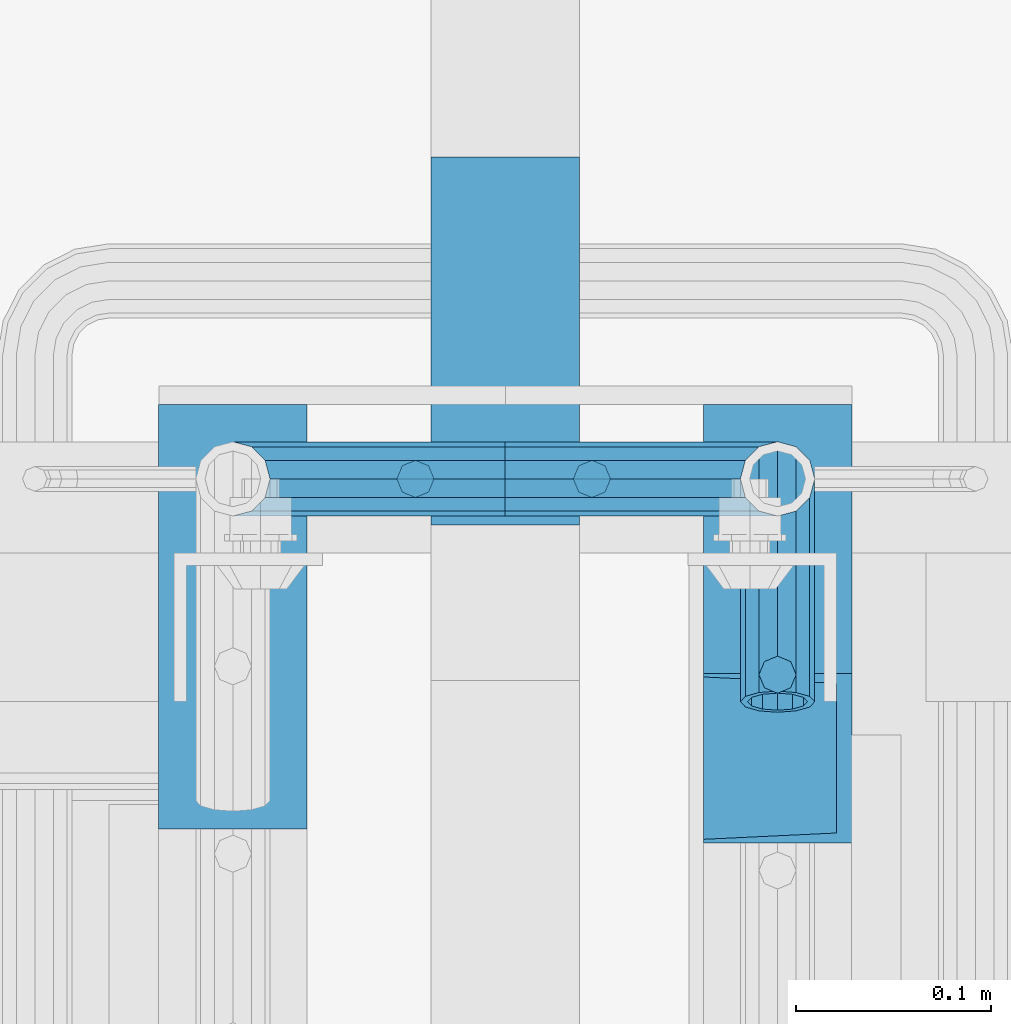
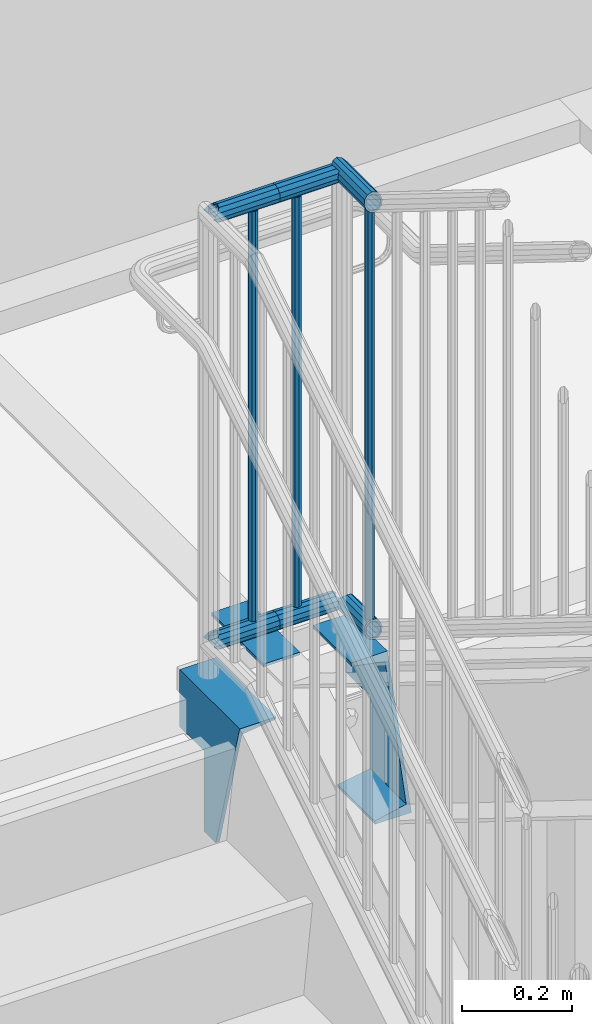
# One storey, part 1274 of 1763: 12 beams, 5 elements without a shape of their own.
"""IFC2X3 building model written with IfcOpenShell, lengths in millimetres."""

from ifc_helpers import new_model, si_unit, frame, origin_with_axes, place, context, subcontext, project, spatial, faceted_brep, material, type_object, element, aggregate, save


model = new_model("IFC2X3")

# Units and contexts
model_context = context("Model", 3, precision=1e-05, world=origin_with_axes())
body_context = subcontext(model_context, "Body", "Model", "MODEL_VIEW")
ifc_project = project(units=[si_unit("LENGTHUNIT", "METRE", prefix="MILLI"), si_unit("AREAUNIT", "SQUARE_METRE"), si_unit("VOLUMEUNIT", "CUBIC_METRE"), si_unit("MASSUNIT", "GRAM", prefix="KILO"), si_unit("TIMEUNIT", "SECOND"), si_unit("PLANEANGLEUNIT", "RADIAN"), si_unit("SOLIDANGLEUNIT", "STERADIAN"), si_unit("THERMODYNAMICTEMPERATUREUNIT", "DEGREE_CELSIUS"), si_unit("LUMINOUSINTENSITYUNIT", "LUMEN")], contexts=[model_context])

# Site, building, storey
site_placement = place(None, origin_with_axes())
site = spatial("IfcSite", under=ifc_project, at=site_placement, CompositionType="ELEMENT")
building_placement = place(site_placement, origin_with_axes())
building = spatial("IfcBuilding", under=site, at=building_placement, Name="Undefined", CompositionType="ELEMENT")
storey_placement = place(building_placement, origin_with_axes())
storey = spatial("IfcBuildingStorey", under=building, at=storey_placement, Name="Undefined", CompositionType="ELEMENT", Elevation=0.0)

# Assembly, beam
assembly_1_placement = place(storey_placement, origin_with_axes())
assembly_1 = element("IfcElementAssembly", 1, at=assembly_1_placement, inside=storey, Name="RAIL", AssemblyPlace="NOTDEFINED", PredefinedType="RIGID_FRAME")
ifc_material_1 = material(Name="STEEL/A513")
beam_type_1 = type_object("IfcBeamType", PredefinedType="NOTDEFINED")
beam_1_placement = place(assembly_1_placement, frame((-85419.6372736932, 36093.4000003696, 2852.7375000151), z_axis=(0.0, 0.0, -1.0), x_axis=(-1.0, 0.0, 0.0)))
beam_1 = element("IfcBeam", 2, at=beam_1_placement, type_object=beam_type_1, material=ifc_material_1, Name="RAIL", context=body_context, shape_type="Brep", body=[
    faceted_brep([(123.202216057922, -9.52500000000146, 16.4977839420935), (123.202216057922, -9.52500000034343, 11.4667123796135), (122.708787619966, -7.68349999999919, 13.3082123799554), (120.650000000009, 0.0, 15.3670000000002), (120.650000000009, 0.0, 19.0500000000002), (122.708787620155, 7.68349999999919, 13.3082123799554), (123.202216057922, 9.52499999965949, 11.4667123802974), (123.202216057922, 9.52500000000146, 16.4977839420935), (139.700000000012, 19.0500000000029, 0.0), (130.175000000017, 16.4977839420972, 9.52500000000009), (130.175000000017, 16.4977839420972, -9.52500000000009), (126.985428438216, 13.3082123799541, 7.68350000000009), (129.044216058261, 15.3669999999984, 0.0), (126.985428438216, 13.3082123799541, -7.68350000000009), (123.202216057922, 9.52499999965949, -11.4667123802974), (123.202216057922, 9.52500000000146, -16.4977839420935), (122.708787620155, 7.68349999999919, -13.3082123799554), (120.650000000009, 0.0, -15.3670000000002), (120.650000000009, 0.0, -19.0500000000002), (123.202216057922, -9.52500000034343, -11.4667123796135), (123.202216057922, -9.52500000000146, -16.4977839420935), (122.708787619966, -7.68349999999919, -13.3082123799554), (139.700000000012, -19.0500000003449, 0.0), (130.175000000017, -16.4977839420972, -9.52500000000009), (130.175000000017, -16.4977839420972, 9.52500000000009), (126.985428437532, -13.3082123799541, -7.68350000000009), (129.044216057577, -15.3669999999984, 0.0), (126.985428437532, -13.3082123799541, 7.68350000000009), (0.0, -16.4977839420899, -9.52500000000146), (0.0, -9.52499999999418, -16.4977839420935), (1.45519152283669e-11, 1.81898940354586e-12, -19.0499999999993), (0.0, 9.52499999999418, -16.4977839420935), (0.0, 16.4977839420899, -9.52500000000146), (0.0, 19.0500000000029, 0.0), (0.0, 16.4977839420899, 9.52500000000146), (0.0, 9.52499999999418, 16.4977839420935), (1.45519152283669e-11, 1.81898940354586e-12, 19.0499999999993), (0.0, -9.52499999999418, 16.4977839420935), (0.0, -16.4977839420899, 9.52500000000146), (0.0, -19.0500000000029, 0.0), (3.63797880709171e-12, -13.3082123799541, -7.68349999999737), (3.63797880709171e-12, -7.68349999999919, -13.3082123799522), (3.63797880709171e-12, 0.0, -15.3669999999956), (3.63797880709171e-12, 7.68349999999919, -13.3082123799522), (3.63797880709171e-12, 13.3082123799541, -7.68349999999737), (4.71409293822944e-08, 15.3669999999984, 0.0), (-1.81898940354586e-12, 13.3082123799541, 7.68349999999919), (-3.63797880709171e-12, 7.68349999999919, 13.3082123799531), (-1.81898940354586e-12, 0.0, 15.3669999999966), (-3.63797880709171e-12, -7.68349999999919, 13.3082123799531), (-1.81898940354586e-12, -13.3082123799541, 7.68349999999919), (4.71409293822944e-08, -15.3669999999984, 0.0)], [[[0, 1, 2, 3, 4]], [[4, 3, 5, 6, 7]], [[8, 9, 10]], [[7, 6, 11, 12, 13, 14, 15, 10, 9]], [[16, 17, 18, 15, 14]], [[19, 20, 18, 17, 21]], [[22, 23, 24]], [[24, 23, 20, 19, 25, 26, 27, 1, 0]], [[28, 29, 20, 23]], [[29, 30, 18, 20]], [[30, 31, 15, 18]], [[31, 32, 10, 15]], [[32, 33, 8, 10]], [[33, 34, 9, 8]], [[34, 35, 7, 9]], [[35, 36, 4, 7]], [[36, 37, 0, 4]], [[37, 38, 24, 0]], [[38, 39, 22, 24]], [[39, 28, 23, 22]], [[38, 37, 36, 35, 34, 33, 32, 31, 30, 29, 28, 39], [40, 41, 42, 43, 44, 45, 46, 47, 48, 49, 50, 51]], [[40, 51, 26, 25]], [[21, 41, 40, 25, 19]], [[42, 41, 21, 17]], [[43, 42, 17, 16]], [[44, 43, 16, 14, 13]], [[45, 44, 13, 12]], [[46, 45, 12, 11]], [[5, 47, 46, 11, 6]], [[48, 47, 5, 3]], [[49, 48, 3, 2]], [[50, 49, 2, 1, 27]], [[51, 50, 27, 26]]]),
])

assembly_2_placement = place(storey_placement, origin_with_axes())
assembly_2 = element("IfcElementAssembly", 3, at=assembly_2_placement, inside=storey, Name="RAIL", AssemblyPlace="NOTDEFINED", PredefinedType="RIGID_FRAME")
beam_2_placement = place(assembly_2_placement, frame((-85322.7997736932, 36093.4000003699, 2852.73750001536), z_axis=(0.0, 0.0, -1.0), x_axis=(-1.0, 0.0, 0.0)))
beam_2 = element("IfcBeam", 4, at=beam_2_placement, type_object=beam_type_1, material=ifc_material_1, Name="RAIL", context=body_context, shape_type="Brep", body=[
    faceted_brep([(-42.9276731446153, 19.0500000000029, 0.0), (-33.4026731446211, 16.4977839420972, -9.52500000000009), (-33.4026731446211, 16.4977839420972, 9.52500000000009), (-33.4026731446211, -16.4977839420972, 9.52500000000009), (-33.4026731446211, -16.4977839420972, -9.52500000000009), (-42.9276731446153, -19.0500000000029, 0.0), (-26.4298892025254, -9.52500000000146, 16.4977839420935), (-26.4298892025254, -9.52499999766587, 11.466712382291), (-30.2131015848136, -13.3082123799541, 7.68350000000009), (-32.2718892048579, -15.3669999999984, 0.0), (-30.2131015848136, -13.3082123799541, -7.68350000000009), (-26.4298892025254, -9.52499999766587, -11.466712382291), (-26.4298892025254, -9.52500000000146, -16.4977839420935), (-23.8776731446123, 0.0, -15.3670000000002), (-23.8776731446123, 0.0, -19.0500000000002), (-25.9364607652824, -7.68349999999919, -13.3082123799554), (-25.9364607640309, 7.68349999999919, -13.3082123799554), (-26.4298892025254, 9.52500000233704, -11.4667123776198), (-26.4298892025254, 9.52500000000146, -16.4977839420935), (-30.2131015801424, 13.3082123799541, -7.68350000000009), (-32.2718892001867, 15.3669999999984, 0.0), (-30.2131015801424, 13.3082123799541, 7.68350000000009), (-26.4298892025254, 9.52500000233704, 11.4667123776198), (-26.4298892025254, 9.52500000000146, 16.4977839420935), (-25.9364607640309, 7.68349999999919, 13.3082123799554), (-23.8776731446123, 2.33558239415288e-09, 15.3670000000002), (-23.8776731446123, 2.33558239415288e-09, 19.0500000000002), (-25.9364607652824, -7.68349999999919, 13.3082123799554), (96.8374999999942, -19.0500000000029, 0.0), (96.8374999999942, -16.4977839420972, 9.52500000000009), (96.8374999999942, -9.52500000000146, 16.4977839420935), (96.8374999999942, 0.0, 19.0500000000002), (96.8374999999942, -9.52500000000146, -16.4977839420935), (96.8374999999942, -16.4977839420972, -9.52500000000009), (96.8374999999942, 0.0, -19.0500000000002), (96.8374999999942, 9.52500000000146, -16.4977839420935), (96.8374999999942, 16.4977839420972, -9.52500000000009), (96.8374999999942, 19.0500000000029, 0.0), (96.8374999999942, 16.4977839420972, 9.52500000000009), (96.8374999999942, 9.52500000000146, 16.4977839420935), (96.8374999999942, -7.68349999999919, 13.3082123799554), (96.8374999999942, 0.0, 15.3670000000002), (96.8374999999942, 7.68349999999919, 13.3082123799554), (96.8374999999942, 13.3082123799541, 7.68350000000009), (96.8374999999942, 15.3669999999984, 0.0), (96.8374999999942, 13.3082123799541, -7.68350000000009), (96.8374999999942, 7.68349999999919, -13.3082123799554), (96.8374999999942, 0.0, -15.3670000000002), (96.8374999999942, -7.68349999999919, -13.3082123799554), (96.8374999999942, -13.3082123799541, -7.68350000000009), (96.8374999999942, -15.3669999999984, 0.0), (96.8374999999942, -13.3082123799541, 7.68350000000009)], [[[0, 1, 2]], [[3, 4, 5]], [[6, 7, 8, 9, 10, 11, 12, 4, 3]], [[13, 14, 12, 11, 15]], [[16, 17, 18, 14, 13]], [[2, 1, 18, 17, 19, 20, 21, 22, 23]], [[23, 22, 24, 25, 26]], [[26, 25, 27, 7, 6]], [[28, 29, 3, 5]], [[29, 30, 6, 3]], [[30, 31, 26, 6]], [[32, 33, 4, 12]], [[34, 32, 12, 14]], [[35, 34, 14, 18]], [[36, 35, 18, 1]], [[37, 36, 1, 0]], [[38, 37, 0, 2]], [[39, 38, 2, 23]], [[31, 39, 23, 26]], [[33, 28, 5, 4]], [[32, 34, 35, 36, 37, 38, 39, 31, 30, 29, 28, 33], [40, 41, 42, 43, 44, 45, 46, 47, 48, 49, 50, 51]], [[42, 41, 25, 24]], [[21, 43, 42, 24, 22]], [[44, 43, 21, 20]], [[45, 44, 20, 19]], [[46, 45, 19, 17, 16]], [[47, 46, 16, 13]], [[48, 47, 13, 15]], [[10, 49, 48, 15, 11]], [[50, 49, 10, 9]], [[51, 50, 9, 8]], [[40, 51, 8, 7, 27]], [[41, 40, 27, 25]]]),
])

# Beam
beam_3_placement = place(assembly_1_placement, frame((-85419.6372736932, 36093.400000372, 3798.88750001511), z_axis=(0.0, 0.0, -1.0), x_axis=(-1.0, 0.0, 0.0)))
beam_3 = element("IfcBeam", 5, at=beam_3_placement, type_object=beam_type_1, material=ifc_material_1, Name="RAIL", context=body_context, shape_type="Brep", body=[
    faceted_brep([(123.202216057922, -9.52500000000146, 16.4977839420935), (123.202216057922, -9.52500000034343, 11.4667123796135), (122.708787619966, -7.68349999999919, 13.3082123799554), (120.650000000009, 0.0, 15.3670000000002), (120.650000000009, 0.0, 19.0500000000002), (122.708787620155, 7.68349999999919, 13.3082123799554), (123.202216057922, 9.52499999965949, 11.4667123802974), (123.202216057922, 9.52500000000146, 16.4977839420935), (139.700000000012, 19.0500000000029, 0.0), (130.175000000017, 16.4977839420972, 9.52500000000009), (130.175000000017, 16.4977839420972, -9.52500000000009), (126.985428438216, 13.3082123799541, 7.68350000000009), (129.044216058261, 15.3669999999984, 0.0), (126.985428438216, 13.3082123799541, -7.68350000000009), (123.202216057922, 9.52499999965949, -11.4667123802974), (123.202216057922, 9.52500000000146, -16.4977839420935), (122.708787620155, 7.68349999999919, -13.3082123799554), (120.650000000009, 0.0, -15.3670000000002), (120.650000000009, 0.0, -19.0500000000002), (123.202216057922, -9.52500000034343, -11.4667123796135), (123.202216057922, -9.52500000000146, -16.4977839420935), (122.708787619966, -7.68349999999919, -13.3082123799554), (139.700000000012, -19.0500000003449, 0.0), (130.175000000017, -16.4977839420972, -9.52500000000009), (130.175000000017, -16.4977839420972, 9.52500000000009), (126.985428437532, -13.3082123799541, -7.68350000000009), (129.044216057577, -15.3669999999984, 0.0), (126.985428437532, -13.3082123799541, 7.68350000000009), (0.0, -16.4977839420899, -9.52500000000146), (0.0, -9.52499999999418, -16.4977839420935), (1.45519152283669e-11, 1.81898940354586e-12, -19.0499999999993), (0.0, 9.52499999999418, -16.4977839420935), (0.0, 16.4977839420899, -9.52500000000146), (0.0, 19.0500000000029, 0.0), (0.0, 16.4977839420899, 9.52500000000146), (0.0, 9.52499999999418, 16.4977839420935), (1.45519152283669e-11, 1.81898940354586e-12, 19.0499999999993), (0.0, -9.52499999999418, 16.4977839420935), (0.0, -16.4977839420899, 9.52500000000146), (0.0, -19.0500000000029, 0.0), (3.63797880709171e-12, -13.3082123799541, -7.68349999999737), (3.63797880709171e-12, -7.68349999999919, -13.3082123799522), (3.63797880709171e-12, 0.0, -15.3669999999956), (3.63797880709171e-12, 7.68349999999919, -13.3082123799522), (3.63797880709171e-12, 13.3082123799541, -7.68349999999737), (4.71409293822944e-08, 15.3669999999984, 0.0), (-1.81898940354586e-12, 13.3082123799541, 7.68349999999919), (-3.63797880709171e-12, 7.68349999999919, 13.3082123799531), (-1.81898940354586e-12, 0.0, 15.3669999999966), (-3.63797880709171e-12, -7.68349999999919, 13.3082123799531), (-1.81898940354586e-12, -13.3082123799541, 7.68349999999919), (4.71409293822944e-08, -15.3669999999984, 0.0)], [[[0, 1, 2, 3, 4]], [[4, 3, 5, 6, 7]], [[8, 9, 10]], [[7, 6, 11, 12, 13, 14, 15, 10, 9]], [[16, 17, 18, 15, 14]], [[19, 20, 18, 17, 21]], [[22, 23, 24]], [[24, 23, 20, 19, 25, 26, 27, 1, 0]], [[28, 29, 20, 23]], [[29, 30, 18, 20]], [[30, 31, 15, 18]], [[31, 32, 10, 15]], [[32, 33, 8, 10]], [[33, 34, 9, 8]], [[34, 35, 7, 9]], [[35, 36, 4, 7]], [[36, 37, 0, 4]], [[37, 38, 24, 0]], [[38, 39, 22, 24]], [[39, 28, 23, 22]], [[38, 37, 36, 35, 34, 33, 32, 31, 30, 29, 28, 39], [40, 41, 42, 43, 44, 45, 46, 47, 48, 49, 50, 51]], [[40, 51, 26, 25]], [[21, 41, 40, 25, 19]], [[42, 41, 21, 17]], [[43, 42, 17, 16]], [[44, 43, 16, 14, 13]], [[45, 44, 13, 12]], [[46, 45, 12, 11]], [[5, 47, 46, 11, 6]], [[48, 47, 5, 3]], [[49, 48, 3, 2]], [[50, 49, 2, 1, 27]], [[51, 50, 27, 26]]]),
])

beam_4_placement = place(assembly_2_placement, frame((-85322.7997736932, 36093.4000003723, 3798.88750001537), z_axis=(0.0, 0.0, -1.0), x_axis=(-1.0, 0.0, 0.0)))
beam_4 = element("IfcBeam", 6, at=beam_4_placement, type_object=beam_type_1, material=ifc_material_1, Name="RAIL", context=body_context, shape_type="Brep", body=[
    faceted_brep([(-42.9276731446153, 19.0500000000029, 0.0), (-33.4026731446211, 16.4977839420972, -9.52500000000009), (-33.4026731446211, 16.4977839420972, 9.52500000000009), (-33.4026731446211, -16.4977839420972, 9.52500000000009), (-33.4026731446211, -16.4977839420972, -9.52500000000009), (-42.9276731446153, -19.0500000000029, 0.0), (-26.4298892025254, -9.52500000000146, 16.4977839420935), (-26.4298892025254, -9.52499999766587, 11.466712382291), (-30.2131015848136, -13.3082123799541, 7.68350000000009), (-32.2718892048579, -15.3669999999984, 0.0), (-30.2131015848136, -13.3082123799541, -7.68350000000009), (-26.4298892025254, -9.52499999766587, -11.466712382291), (-26.4298892025254, -9.52500000000146, -16.4977839420935), (-23.8776731446123, 0.0, -15.3670000000002), (-23.8776731446123, 0.0, -19.0500000000002), (-25.9364607652824, -7.68349999999919, -13.3082123799554), (-25.9364607640309, 7.68349999999919, -13.3082123799554), (-26.4298892025254, 9.52500000233704, -11.4667123776198), (-26.4298892025254, 9.52500000000146, -16.4977839420935), (-30.2131015801424, 13.3082123799541, -7.68350000000009), (-32.2718892001867, 15.3669999999984, 0.0), (-30.2131015801424, 13.3082123799541, 7.68350000000009), (-26.4298892025254, 9.52500000233704, 11.4667123776198), (-26.4298892025254, 9.52500000000146, 16.4977839420935), (-25.9364607640309, 7.68349999999919, 13.3082123799554), (-23.8776731446123, 2.33558239415288e-09, 15.3670000000002), (-23.8776731446123, 2.33558239415288e-09, 19.0500000000002), (-25.9364607652824, -7.68349999999919, 13.3082123799554), (96.8374999999942, -19.0500000000029, 0.0), (96.8374999999942, -16.4977839420972, 9.52500000000009), (96.8374999999942, -9.52500000000146, 16.4977839420935), (96.8374999999942, 0.0, 19.0500000000002), (96.8374999999942, -9.52500000000146, -16.4977839420935), (96.8374999999942, -16.4977839420972, -9.52500000000009), (96.8374999999942, 0.0, -19.0500000000002), (96.8374999999942, 9.52500000000146, -16.4977839420935), (96.8374999999942, 16.4977839420972, -9.52500000000009), (96.8374999999942, 19.0500000000029, 0.0), (96.8374999999942, 16.4977839420972, 9.52500000000009), (96.8374999999942, 9.52500000000146, 16.4977839420935), (96.8374999999942, -7.68349999999919, 13.3082123799554), (96.8374999999942, 0.0, 15.3670000000002), (96.8374999999942, 7.68349999999919, 13.3082123799554), (96.8374999999942, 13.3082123799541, 7.68350000000009), (96.8374999999942, 15.3669999999984, 0.0), (96.8374999999942, 13.3082123799541, -7.68350000000009), (96.8374999999942, 7.68349999999919, -13.3082123799554), (96.8374999999942, 0.0, -15.3670000000002), (96.8374999999942, -7.68349999999919, -13.3082123799554), (96.8374999999942, -13.3082123799541, -7.68350000000009), (96.8374999999942, -15.3669999999984, 0.0), (96.8374999999942, -13.3082123799541, 7.68350000000009)], [[[0, 1, 2]], [[3, 4, 5]], [[6, 7, 8, 9, 10, 11, 12, 4, 3]], [[13, 14, 12, 11, 15]], [[16, 17, 18, 14, 13]], [[2, 1, 18, 17, 19, 20, 21, 22, 23]], [[23, 22, 24, 25, 26]], [[26, 25, 27, 7, 6]], [[28, 29, 3, 5]], [[29, 30, 6, 3]], [[30, 31, 26, 6]], [[32, 33, 4, 12]], [[34, 32, 12, 14]], [[35, 34, 14, 18]], [[36, 35, 18, 1]], [[37, 36, 1, 0]], [[38, 37, 0, 2]], [[39, 38, 2, 23]], [[31, 39, 23, 26]], [[33, 28, 5, 4]], [[32, 34, 35, 36, 37, 38, 39, 31, 30, 29, 28, 33], [40, 41, 42, 43, 44, 45, 46, 47, 48, 49, 50, 51]], [[42, 41, 25, 24]], [[21, 43, 42, 24, 22]], [[44, 43, 21, 20]], [[45, 44, 20, 19]], [[46, 45, 19, 17, 16]], [[47, 46, 16, 13]], [[48, 47, 13, 15]], [[10, 49, 48, 15, 11]], [[50, 49, 10, 9]], [[51, 50, 9, 8]], [[40, 51, 8, 7, 27]], [[41, 40, 27, 25]]]),
])

beam_5_placement = place(assembly_2_placement, frame((-85279.8721005486, 36093.4000003723, 2852.73750001571), z_axis=(0.0, 0.0, 1.0), x_axis=(0.0, -1.0, 0.0)))
beam_5 = element("IfcBeam", 7, at=beam_5_placement, type_object=beam_type_1, material=ifc_material_1, Name="RAIL", context=body_context, shape_type="Brep", body=[
    faceted_brep([(0.0, 19.0500000000029, 0.0), (9.52499999467545, 16.4977839420899, -9.52500000000009), (9.52500000096188, 16.4977839420899, 9.52500000000009), (9.52500000096188, -16.4977839420899, 9.52500000000009), (9.52499999467545, -16.4977839420899, -9.52500000000009), (0.0, -19.0500000000029, 0.0), (16.4977839430576, -9.52499999999418, 16.4977839420935), (16.4977839367712, -9.52500000031432, 11.4667123796353), (12.7145715571314, -13.3082123799541, 7.68350000000009), (10.6557839370871, -15.3669999999984, 0.0), (12.7145715571314, -13.3082123799541, -7.68350000000009), (16.4977839367712, -9.52500000031432, -11.4667123796353), (16.4977839367712, -9.52499999999418, -16.4977839420935), (19.0499999946769, 0.0, -15.3670000000002), (19.0499999946769, 0.0, -19.0500000000002), (16.9912123747126, -7.68349999999919, -13.3082123799554), (16.9912123745453, 7.68349999999919, -13.3082123799554), (16.4977839367712, 9.52499999967404, -11.4667123802756), (16.4977839367712, 9.52499999999418, -16.4977839420935), (12.7145715564911, 13.3082123799541, -7.68350000000009), (10.6557839364468, 15.3669999999984, 0.0), (12.7145715564911, 13.3082123799541, 7.68350000000009), (16.4977839367712, 9.52499999967404, 11.4667123802756), (16.4977839430576, 9.52499999999418, 16.4977839420935), (16.9912123745453, 7.68349999999919, 13.3082123799554), (19.0499999946769, -3.20142135024071e-10, 15.3670000000002), (19.0500000009633, 0.0, 19.0500000000002), (16.9912123747126, -7.68349999999919, 13.3082123799554), (114.299998441489, -19.0500000000029, 0.0), (111.58373004643, -16.4977839420899, 9.52499999999964), (109.595283574254, -9.52499999999418, 16.4977839420935), (108.867461651371, 0.0, 19.0500000000002), (119.004713308725, -9.52499999999418, -16.4977839420935), (117.016266836548, -16.4977839420899, -9.52499999999964), (119.732535231604, 0.0, -19.0500000000002), (119.004713308725, 9.52499999999418, -16.4977839420935), (117.016266836548, 16.4977839420899, -9.52499999999964), (114.299998441489, 19.0500000000029, 0.0), (111.58373004643, 16.4977839420899, 9.52499999999964), (109.595283574254, 9.52499999999418, 16.4977839420935), (110.504861781919, -7.68349999999919, 13.3082123799559), (109.917752097459, 0.0, 15.3670000000002), (110.504861781919, 7.68349999999919, 13.3082123799559), (112.108875269474, 13.3082123799541, 7.68350000000009), (114.299998441489, 15.3669999999984, 0.0), (116.491121613501, 13.3082123799541, -7.68350000000009), (118.095135101059, 7.68349999999919, -13.3082123799559), (118.682244785516, 0.0, -15.3670000000002), (118.095135101059, -7.68349999999919, -13.3082123799559), (116.491121613501, -13.3082123799541, -7.68350000000009), (114.299998441489, -15.3669999999984, 0.0), (112.108875269474, -13.3082123799541, 7.68350000000009)], [[[0, 1, 2]], [[3, 4, 5]], [[6, 7, 8, 9, 10, 11, 12, 4, 3]], [[13, 14, 12, 11, 15]], [[16, 17, 18, 14, 13]], [[2, 1, 18, 17, 19, 20, 21, 22, 23]], [[23, 22, 24, 25, 26]], [[26, 25, 27, 7, 6]], [[3, 5, 28, 29]], [[6, 3, 29, 30]], [[26, 6, 30, 31]], [[32, 33, 4, 12]], [[34, 32, 12, 14]], [[35, 34, 14, 18]], [[36, 35, 18, 1]], [[37, 36, 1, 0]], [[0, 2, 38, 37]], [[2, 23, 39, 38]], [[23, 26, 31, 39]], [[33, 28, 5, 4]], [[32, 34, 35, 36, 37, 38, 39, 31, 30, 29, 28, 33], [40, 41, 42, 43, 44, 45, 46, 47, 48, 49, 50, 51]], [[42, 41, 25, 24]], [[21, 43, 42, 24, 22]], [[44, 43, 21, 20]], [[45, 44, 20, 19]], [[46, 45, 19, 17, 16]], [[47, 46, 16, 13]], [[48, 47, 13, 15]], [[10, 49, 48, 15, 11]], [[50, 49, 10, 9]], [[51, 50, 9, 8]], [[40, 51, 8, 7, 27]], [[41, 40, 27, 25]]]),
])

beam_6_placement = place(assembly_2_placement, frame((-85279.8721005486, 35979.1000012715, 3798.88750001537), z_axis=(0.0, 0.0, -1.0), x_axis=(0.0, 1.0, 0.0)))
beam_6 = element("IfcBeam", 8, at=beam_6_placement, type_object=beam_type_1, material=ifc_material_1, Name="RAIL", context=body_context, shape_type="Brep", body=[
    faceted_brep([(4.71409293822944e-08, -15.3669999999984, 0.0), (-2.19112304952796, -13.3082123799541, 7.68350000000009), (106.616499090538, -13.3082123799541, 7.68350000000009), (114.299998441489, -15.3669999999984, 0.0), (-3.79513653708273, -7.68349999999919, 13.3082123799559), (100.991786710583, -7.68349999999919, 13.3082123799554), (-4.38224622154303, 0.0, 15.3670000000002), (98.9329990905389, 0.0, 15.3670000000002), (-3.79513653708273, 7.68349999999919, 13.3082123799559), (100.991786710583, 7.68349999999919, 13.3082123799554), (-2.19112304952796, 13.3082123799541, 7.68350000000009), (106.616499090538, 13.3082123799541, 7.68350000000009), (4.71409293822944e-08, 15.3669999999984, 0.0), (114.299998441489, 15.3669999999984, 0.0), (2.19112329449854, 13.3082123799541, -7.68350000000009), (121.983499090536, 13.3082123799541, -7.68350000000009), (3.79513678205694, 7.68349999999919, -13.3082123799559), (127.608211470491, 7.68349999999919, -13.3082123799554), (4.38224646651361, 0.0, -15.3670000000002), (129.666999090536, 0.0, -15.3670000000002), (3.79513678205694, -7.68349999999919, -13.3082123799559), (127.608211470491, -7.68349999999919, -13.3082123799554), (2.19112329449854, -13.3082123799541, -7.68350000000009), (121.983499090536, -13.3082123799541, -7.68350000000009), (0.0, -19.0500000000029, 0.0), (2.71626851754627, -16.4977839420899, -9.52499999999964), (123.824999090539, -16.4977839420899, -9.52500000000009), (114.299998441489, -19.0500000000029, 0.0), (4.70471498972256, -9.52499999999418, -16.4977839420935), (130.797783032634, -9.52499999999418, -16.4977839420935), (5.43253691260543, 0.0, -19.0500000000002), (133.34999909054, 0.0, -19.0500000000002), (4.70471498972256, 9.52499999999418, -16.4977839420935), (130.797783032634, 9.52499999999418, -16.4977839420935), (2.71626851754627, 16.4977839420899, -9.52499999999964), (123.824999090539, 16.4977839420899, -9.52500000000009), (0.0, 19.0500000000029, 0.0), (114.299998441489, 19.0500000000029, 0.0), (-2.71626827257205, 16.4977839420899, 9.52499999999964), (104.774998552017, 16.4977839420899, 9.52499999999964), (-4.70471474474834, 9.52499999999418, 16.4977839420935), (97.8022146099247, 9.52499999999418, 16.4977839420935), (-5.43253666763121, 0.0, 19.0500000000002), (95.249998552019, 0.0, 19.0500000000002), (-4.70471474474834, -9.52499999999418, 16.4977839420935), (97.8022146099247, -9.52499999999418, 16.4977839420935), (-2.71626827257205, -16.4977839420899, 9.52499999999964), (104.774998552017, -16.4977839420899, 9.52499999999964)], [[[0, 1, 2, 3]], [[1, 4, 5, 2]], [[4, 6, 7, 5]], [[6, 8, 9, 7]], [[8, 10, 11, 9]], [[10, 12, 13, 11]], [[12, 14, 15, 13]], [[14, 16, 17, 15]], [[16, 18, 19, 17]], [[18, 20, 21, 19]], [[20, 22, 23, 21]], [[22, 0, 3, 23]], [[24, 25, 26, 27]], [[25, 28, 29, 26]], [[28, 30, 31, 29]], [[30, 32, 33, 31]], [[32, 34, 35, 33]], [[34, 36, 37, 35]], [[36, 38, 39, 37]], [[38, 40, 41, 39]], [[40, 42, 43, 41]], [[42, 44, 45, 43]], [[44, 46, 47, 45]], [[46, 24, 27, 47]], [[29, 31, 33, 35, 37, 39, 41, 43, 45, 47, 27, 26], [5, 7, 9, 11, 13, 15, 17, 19, 21, 23, 3, 2]], [[46, 44, 42, 40, 38, 36, 34, 32, 30, 28, 25, 24], [22, 20, 18, 16, 14, 12, 10, 8, 6, 4, 1, 0]]]),
])

# Assembly, beam
assembly_3_placement = place(storey_placement, origin_with_axes())
assembly_3 = element("IfcElementAssembly", 9, at=assembly_3_placement, inside=storey, Name="STRINGER", AssemblyPlace="NOTDEFINED", PredefinedType="RIGID_FRAME")
ifc_material_2 = material(Name="STEEL/A36")
beam_type_2 = type_object("IfcBeamType", Name="C12X20.7", PredefinedType="NOTDEFINED")
beam_7_placement = place(assembly_3_placement, frame((-85559.3372737272, 35913.819135954, 2630.48749999484), z_axis=(0.0, 0.0, 1.0), x_axis=(0.0, 1.0, 0.0)))
beam_7 = element("IfcBeam", 10, at=beam_7_placement, type_object=beam_type_2, material=ifc_material_2, Name="STRINGER", ObjectType="C12X20.7", context=body_context, shape_type="Brep", body=[
    faceted_brep([(128.780864415559, 30.1625000000058, -134.6749275), (81.8325404486168, 30.1625000000058, -134.6749275), (86.885185425861, 30.1624999999476, -152.4), (128.780864415567, 30.1625000000058, -152.4), (0.0, -38.1000000000004, 152.4), (1.81083327635861, -38.1000000000058, 146.04746), (217.680864415568, -38.1000000000058, 146.04746), (217.680864415568, -38.1000000000058, 152.4), (0.0, 38.1000000000004, 152.4), (217.680864415568, 38.1000000000058, 152.4), (128.780864415567, 38.1000000000058, -152.4), (128.780864415567, 38.1000000000058, 25.4000000044698), (128.780864415567, 30.1625000000058, 25.4000000044698), (128.780864415567, 30.1625000000058, -132.074921396485), (86.885185425861, 38.1000000000058, -152.4), (81.0913921244137, 30.1625000000058, -132.074921396485), (5.05264620630624, 30.1625000000058, 134.6749275), (217.680864415568, 30.1625000000058, 134.6749275), (217.680864415568, 30.1625000000058, 25.4000000044698), (217.680864415568, 38.1000000000058, 25.4000000044698)], [[[0, 1, 2, 3]], [[4, 5, 6, 7]], [[8, 4, 7, 9]], [[10, 11, 12, 13, 0, 3]], [[14, 10, 3, 2]], [[15, 16, 5, 4, 8, 14, 2, 1]], [[5, 16, 17, 6]], [[9, 7, 6, 17, 18, 19]], [[10, 14, 8, 9, 19, 11]], [[18, 12, 11, 19]], [[17, 16, 15, 1, 0, 13, 12, 18]]]),
])
aggregate(assembly_3, [beam_7])

assembly_4_placement = place(storey_placement, origin_with_axes())
assembly_4 = element("IfcElementAssembly", 11, at=assembly_4_placement, inside=storey, Name="STRINGER", AssemblyPlace="NOTDEFINED", PredefinedType="RIGID_FRAME")
beam_8_placement = place(assembly_4_placement, frame((-85279.8721013136, 36106.1000012579, 2630.48749999556), z_axis=(0.0, 0.0, 1.0), x_axis=(0.0, -1.0, 0.0)))
beam_8 = element("IfcBeam", 12, at=beam_8_placement, type_object=beam_type_2, material=ifc_material_2, Name="STRINGER", ObjectType="C12X20.7", context=body_context, shape_type="Brep", body=[
    faceted_brep([(63.5000008883653, 30.1625000000058, 25.4000000191577), (63.5000008883653, 38.1000000000058, 25.4000000191577), (63.5000008883653, 38.1000000000058, -152.4), (63.5000008883653, -38.1000000000058, -152.4), (63.5000008883653, -38.1000000000058, -146.04746), (63.5000008883653, 30.1625000000058, -134.6749275), (-25.3999991117889, 30.1625000000058, 25.4000000191577), (-25.3999991117889, 38.1000000000058, 25.4000000191577), (-25.3999991117889, 38.1000000000058, 152.4), (-25.3999991117889, -38.1000000000058, 152.4), (112.513235167658, -38.1000000000058, 152.4), (112.513235167658, 38.1000000000058, 152.4), (-25.3999991117889, -38.1000000000058, 146.04746), (114.324805102602, -38.1000000000058, 146.04746), (-25.3999991117889, 30.1625000000058, 134.6749275), (117.567939024026, 30.1625000000058, 134.6749275), (194.37911995317, 30.1625000000058, -134.6749275), (197.622253874593, -38.1000000000058, -146.04746), (199.433823809537, -38.1000000000058, -152.4), (199.433823809537, 38.1000000000058, -152.4)], [[[0, 1, 2, 3, 4, 5]], [[6, 7, 1, 0]], [[8, 9, 10, 11]], [[9, 12, 13, 10]], [[12, 14, 15, 13]], [[10, 13, 15, 16, 17, 18, 19, 11]], [[17, 16, 5, 4]], [[18, 17, 4, 3]], [[19, 18, 3, 2]], [[8, 11, 19, 2, 1, 7]], [[14, 12, 9, 8, 7, 6]], [[16, 15, 14, 6, 0, 5]]]),
])
aggregate(assembly_4, [beam_8])

assembly_5_placement = place(storey_placement, origin_with_axes())
assembly_5 = element("IfcElementAssembly", 13, at=assembly_5_placement, inside=storey, Name="ref.", AssemblyPlace="NOTDEFINED", PredefinedType="NOTDEFINED")
ifc_material_3 = material()
beam_type_3 = type_object("IfcBeamType", PredefinedType="NOTDEFINED")
beam_9_placement = place(assembly_5_placement, frame((-85419.6372736932, 36069.7867660397, 2779.7125000151), z_axis=(-1.0, 0.0, 0.0), x_axis=(0.0, 1.0, 0.0)))
beam_9 = element("IfcBeam", 14, at=beam_9_placement, type_object=beam_type_3, material=ifc_material_3, Name="ref.", context=body_context, shape_type="Brep", body=[
    faceted_brep([(0.0, 3.17500000000018, -38.0999999999985), (0.0, 3.17500000000018, 38.0999999999985), (188.713234329807, 3.17500000000018, 38.1000000000058), (188.713234329807, 3.17500000000018, -38.1000000000058), (0.0, -3.17500000000018, 38.0999999999985), (188.713234329807, -3.17500000000018, 38.1000000000058), (0.0, -3.17500000000018, -38.0999999999985), (188.713234329807, -3.17500000000018, -38.1000000000058)], [[[0, 1, 2, 3]], [[1, 4, 5, 2]], [[4, 6, 7, 5]], [[6, 0, 3, 7]], [[5, 7, 3, 2]], [[6, 4, 1, 0]]]),
])
aggregate(assembly_5, [beam_9])

# Beam
beam_type_4 = type_object("IfcBeamType", PredefinedType="NOTDEFINED")
beam_10_placement = place(assembly_2_placement, frame((-85375.1221005486, 36093.4000003704, 3798.88750001506), z_axis=(1.0, 0.0, 0.0), x_axis=(0.0, 0.0, -1.0)))
beam_10 = element("IfcBeam", 15, at=beam_10_placement, type_object=beam_type_4, material=ifc_material_2, Name="PICKET", context=body_context, shape_type="Brep", body=[
    faceted_brep([(19.0499999999092, -9.52500000000146, 0.0), (19.0499999999092, -6.73519209080405, -6.73519209079677), (927.099999996084, -6.73519209080405, -6.73519209079677), (927.099999996084, -9.52500000000146, 0.0), (19.0499999999092, 0.0, -9.52499999999418), (927.099999996084, 0.0, -9.52499999999418), (19.0499999999092, 6.73519209080405, -6.73519209079677), (927.099999996084, 6.73519209080405, -6.73519209079677), (19.0499999999092, 9.52500000000146, 0.0), (927.099999996084, 9.52500000000146, 0.0), (19.0499999999092, 6.73519209080405, 6.73519209079677), (927.099999996084, 6.73519209080405, 6.73519209079677), (19.0499999999092, 0.0, 9.52499999999418), (927.099999996084, 0.0, 9.52499999999418), (19.0499999999092, -6.73519209080405, 6.73519209079677), (927.099999996084, -6.73519209080405, 6.73519209079677)], [[[0, 1, 2, 3]], [[1, 4, 5, 2]], [[4, 6, 7, 5]], [[6, 8, 9, 7]], [[8, 10, 11, 9]], [[10, 12, 13, 11]], [[12, 14, 15, 13]], [[14, 0, 3, 15]], [[5, 7, 9, 11, 13, 15, 3, 2]], [[14, 12, 10, 8, 6, 4, 1, 0]]]),
])

beam_11_placement = place(assembly_1_placement, frame((-85465.6747736932, 36093.4000003704, 3798.887500015), z_axis=(1.0, 0.0, 0.0), x_axis=(0.0, 0.0, -1.0)))
beam_11 = element("IfcBeam", 16, at=beam_11_placement, type_object=beam_type_4, material=ifc_material_2, Name="PICKET", context=body_context, shape_type="Brep", body=[
    faceted_brep([(19.0499999999092, -9.52500000000146, 0.0), (19.0499999999092, -6.73519209080405, -6.73519209079677), (927.099999996084, -6.73519209080405, -6.73519209079677), (927.099999996084, -9.52500000000146, 0.0), (19.0499999999092, 0.0, -9.52499999999418), (927.099999996084, 0.0, -9.52499999999418), (19.0499999999092, 6.73519209080405, -6.73519209079677), (927.099999996084, 6.73519209080405, -6.73519209079677), (19.0499999999092, 9.52500000000146, 0.0), (927.099999996084, 9.52500000000146, 0.0), (19.0499999999092, 6.73519209080405, 6.73519209079677), (927.099999996084, 6.73519209080405, 6.73519209079677), (19.0499999999092, 0.0, 9.52499999999418), (927.099999996084, 0.0, 9.52499999999418), (19.0499999999092, -6.73519209080405, 6.73519209079677), (927.099999996084, -6.73519209080405, 6.73519209079677)], [[[0, 1, 2, 3]], [[1, 4, 5, 2]], [[4, 6, 7, 5]], [[6, 8, 9, 7]], [[8, 10, 11, 9]], [[10, 12, 13, 11]], [[12, 14, 15, 13]], [[14, 0, 3, 15]], [[5, 7, 9, 11, 13, 15, 3, 2]], [[14, 12, 10, 8, 6, 4, 1, 0]]]),
])

aggregate(assembly_1, [beam_11, beam_1, beam_3])

beam_12_placement = place(assembly_2_placement, frame((-85279.8721005486, 35992.9545458097, 3798.88750001537), z_axis=(1.0, 0.0, 0.0), x_axis=(0.0, 0.0, -1.0)))
beam_12 = element("IfcBeam", 17, at=beam_12_placement, type_object=beam_type_4, material=ifc_material_2, Name="PICKET", context=body_context, shape_type="Brep", body=[
    faceted_brep([(19.0499999999092, -9.52500000000146, 0.0), (19.0499999999092, -6.73519209080405, -6.73519209079677), (927.099999996084, -6.73519209080405, -6.73519209079677), (927.099999996084, -9.52500000000146, 0.0), (19.0499999999092, 0.0, -9.52499999999418), (927.099999996084, 0.0, -9.52499999999418), (19.0499999999092, 6.73519209080405, -6.73519209079677), (927.099999996084, 6.73519209080405, -6.73519209079677), (19.0499999999092, 9.52500000000146, 0.0), (927.099999996084, 9.52500000000146, 0.0), (19.0499999999092, 6.73519209080405, 6.73519209079677), (927.099999996084, 6.73519209080405, 6.73519209079677), (19.0499999999092, 0.0, 9.52499999999418), (927.099999996084, 0.0, 9.52499999999418), (19.0499999999092, -6.73519209080405, 6.73519209079677), (927.099999996084, -6.73519209080405, 6.73519209079677)], [[[0, 1, 2, 3]], [[1, 4, 5, 2]], [[4, 6, 7, 5]], [[6, 8, 9, 7]], [[8, 10, 11, 9]], [[10, 12, 13, 11]], [[12, 14, 15, 13]], [[14, 0, 3, 15]], [[5, 7, 9, 11, 13, 15, 3, 2]], [[14, 12, 10, 8, 6, 4, 1, 0]]]),
])

aggregate(assembly_2, [beam_10, beam_2, beam_4, beam_12, beam_5, beam_6])

save(model, "model.ifc")
